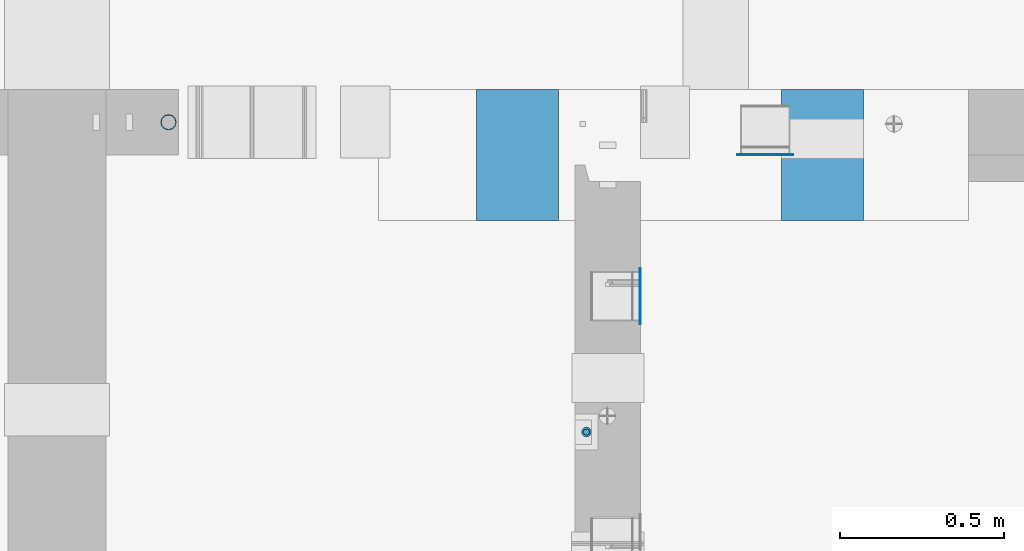
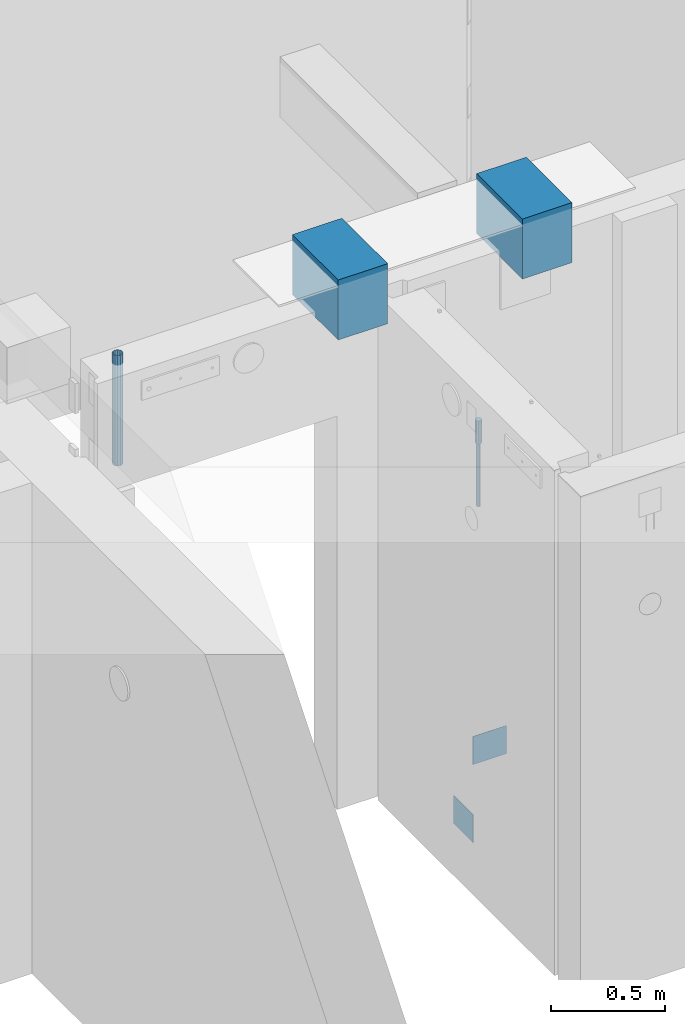
# One storey, part 12 of 264: 7 columns, 6 elements without a shape of their own.
"""IFC2X3 building model written with IfcOpenShell, lengths in millimetres."""

from ifc_helpers import new_model, si_unit, frame, origin_with_axes, place, context, subcontext, project, spatial, faceted_brep, material, type_object, element, aggregate, save


model = new_model("IFC2X3")

# Units and contexts
model_context = context("Model", 3, precision=1e-05, world=origin_with_axes())
body_context = subcontext(model_context, "Body", "Model", "MODEL_VIEW")
ifc_project = project(units=[si_unit("LENGTHUNIT", "METRE", prefix="MILLI"), si_unit("AREAUNIT", "SQUARE_METRE"), si_unit("VOLUMEUNIT", "CUBIC_METRE"), si_unit("MASSUNIT", "GRAM", prefix="KILO"), si_unit("TIMEUNIT", "SECOND"), si_unit("PLANEANGLEUNIT", "RADIAN"), si_unit("SOLIDANGLEUNIT", "STERADIAN"), si_unit("THERMODYNAMICTEMPERATUREUNIT", "DEGREE_CELSIUS"), si_unit("LUMINOUSINTENSITYUNIT", "LUMEN")], contexts=[model_context])

# Site, building, storey
site_placement = place(None, origin_with_axes())
site = spatial("IfcSite", under=ifc_project, at=site_placement, CompositionType="ELEMENT")
building_placement = place(site_placement, origin_with_axes())
building = spatial("IfcBuilding", under=site, at=building_placement, CompositionType="ELEMENT")
storey_placement = place(building_placement, origin_with_axes())
storey = spatial("IfcBuildingStorey", under=building, at=storey_placement, Name="K", CompositionType="ELEMENT", Elevation=0.0)

# Assembly, column
assembly_1_placement = place(storey_placement, origin_with_axes())
assembly_1 = element("IfcElementAssembly", 1, at=assembly_1_placement, inside=storey, AssemblyPlace="NOTDEFINED", PredefinedType="REINFORCEMENT_UNIT")
ifc_material_1 = material()
column_type_1 = type_object("IfcColumnType", Name="D30", PredefinedType="NOTDEFINED")
column_1_placement = place(assembly_1_placement, frame((15165.0, 16035.0017200341, 81167.5), z_axis=(-1.0, 3.00000001838171e-08, 0.0), x_axis=(0.0, 0.0, 1.0)))
column_1 = element("IfcColumn", 2, at=column_1_placement, type_object=column_type_1, material=ifc_material_1, ObjectType="D30", context=body_context, shape_type="Brep", body=[
    faceted_brep([(0.0, -15.0, 0.0), (0.0, -12.9903810567666, -7.5), (125.0, -12.9903810567666, -7.5), (125.0, -15.0, 0.0), (0.0, -7.5, -12.9903810567666), (125.0, -7.5, -12.9903810567666), (0.0, 0.0, -15.0), (125.0, 0.0, -15.0), (0.0, 7.5, -12.9903810567666), (125.0, 7.5, -12.9903810567666), (0.0, 12.9903810567666, -7.5), (125.0, 12.9903810567666, -7.5), (0.0, 15.0, 0.0), (125.0, 15.0, 0.0), (0.0, 12.9903810567666, 7.5), (125.0, 12.9903810567666, 7.5), (0.0, 7.5, 12.9903810567666), (125.0, 7.5, 12.9903810567666), (0.0, 0.0, 15.0), (125.0, 0.0, 15.0), (0.0, -7.5, 12.9903810567666), (125.0, -7.5, 12.9903810567666), (0.0, -12.9903810567666, 7.5), (125.0, -12.9903810567666, 7.5)], [[[0, 1, 2, 3]], [[1, 4, 5, 2]], [[4, 6, 7, 5]], [[6, 8, 9, 7]], [[8, 10, 11, 9]], [[10, 12, 13, 11]], [[12, 14, 15, 13]], [[14, 16, 17, 15]], [[16, 18, 19, 17]], [[18, 20, 21, 19]], [[20, 22, 23, 21]], [[22, 0, 3, 23]], [[5, 7, 9, 11, 13, 15, 17, 19, 21, 23, 3, 2]], [[22, 20, 18, 16, 14, 12, 10, 8, 6, 4, 1, 0]]]),
])

# Assemblies, column
assembly_2_placement = place(storey_placement, origin_with_axes())
assembly_2 = element("IfcElementAssembly", 3, at=assembly_2_placement, inside=storey, AssemblyPlace="NOTDEFINED", PredefinedType="REINFORCEMENT_UNIT")
assembly_3_placement = place(assembly_2_placement, origin_with_axes())
assembly_3 = element("IfcElementAssembly", 4, at=assembly_3_placement, Name="Steel Assembly", AssemblyPlace="NOTDEFINED", PredefinedType="NOTDEFINED")
ifc_material_2 = material(Name="Undefined")
column_type_2 = type_object("IfcColumnType", PredefinedType="NOTDEFINED")
column_2_placement = place(assembly_3_placement, frame((15710.4603214753, 16881.0002441656, 78775.1200050936), z_axis=(0.0, -1.0, 0.0), x_axis=(0.0, 0.0, 1.0)))
column_2 = element("IfcColumn", 5, at=column_2_placement, type_object=column_type_2, material=ifc_material_2, Name="SPK3", context=body_context, shape_type="Brep", body=[
    faceted_brep([(0.0, 85.0, -1.0), (0.0, 85.0, 1.0), (150.0, 85.0, 1.0), (150.0, 85.0, -1.0), (0.0, -85.0, 1.0), (150.0, -85.0, 1.0), (0.0, -85.0, -1.0), (150.0, -85.0, -1.0)], [[[0, 1, 2, 3]], [[1, 4, 5, 2]], [[4, 6, 7, 5]], [[6, 0, 3, 7]], [[5, 7, 3, 2]], [[6, 4, 1, 0]]]),
])
aggregate(assembly_3, [column_2])

# Assembly, column
assembly_4_placement = place(assembly_1_placement, origin_with_axes())
assembly_4 = element("IfcElementAssembly", 6, at=assembly_4_placement, Name="Steel Assembly", AssemblyPlace="NOTDEFINED", PredefinedType="NOTDEFINED")
column_3_placement = place(assembly_4_placement, frame((15328.9997558344, 16449.5113457082, 78775.1200050936), z_axis=(1.0, 0.0, 0.0), x_axis=(0.0, 0.0, 1.0)))
column_3 = element("IfcColumn", 7, at=column_3_placement, type_object=column_type_2, material=ifc_material_2, Name="SPK3", context=body_context, shape_type="Brep", body=[
    faceted_brep([(0.0, 85.0, -1.0), (0.0, 85.0, 1.0), (150.0, 85.0, 1.0), (150.0, 85.0, -1.0), (0.0, -85.0, 1.0), (150.0, -85.0, 1.0), (0.0, -85.0, -1.0), (150.0, -85.0, -1.0)], [[[0, 1, 2, 3]], [[1, 4, 5, 2]], [[4, 6, 7, 5]], [[6, 0, 3, 7]], [[5, 7, 3, 2]], [[6, 4, 1, 0]]]),
])
aggregate(assembly_4, [column_3])

# Column
ifc_material_3 = material()
column_type_3 = type_object("IfcColumnType", Name="48.3X2.6", PredefinedType="NOTDEFINED")
column_4_placement = place(assembly_2_placement, frame((13889.9991042544, 16980.0, 80931.0), z_axis=(-1.0, 3.00000001838171e-08, 0.0), x_axis=(0.0, 0.0, 1.0)))
column_4 = element("IfcColumn", 8, at=column_4_placement, type_object=column_type_3, material=ifc_material_3, ObjectType="48.3X2.6", context=body_context, shape_type="Brep", body=[
    faceted_brep([(0.0, -21.5499999999993, 0.0), (0.0, -18.6628474515564, 10.7750000000015), (589.0, -18.6628474515564, 10.7749999999996), (589.0, -21.5499999999993, 0.0), (0.0, -10.7750000000015, 18.6628474515564), (589.0, -10.7750000000015, 18.6628474515546), (0.0, 0.0, 21.5499999999993), (589.0, 0.0, 21.5499999999993), (0.0, 10.7750000000015, 18.6628474515564), (589.0, 10.7750000000015, 18.6628474515546), (0.0, 18.6628474515564, 10.7750000000015), (589.0, 18.6628474515564, 10.7749999999996), (0.0, 21.5499999999993, 0.0), (589.0, 21.5499999999993, 0.0), (0.0, 18.6628474515564, -10.7750000000015), (589.0, 18.6628474515564, -10.7749999999996), (0.0, 10.7750000000015, -18.6628474515564), (589.0, 10.7750000000015, -18.6628474515546), (0.0, 0.0, -21.5499999999993), (589.0, 0.0, -21.5499999999993), (0.0, -10.7750000000015, -18.6628474515564), (589.0, -10.7750000000015, -18.6628474515546), (0.0, -18.6628474515564, -10.7750000000015), (589.0, -18.6628474515564, -10.7749999999996), (0.0, -24.1500000000015, 0.0), (0.0, -20.9145135013932, -12.0750000000007), (589.0, -20.9145135013932, -12.0750000000007), (589.0, -24.1500000000015, 0.0), (0.0, -12.0750000000007, -20.9145135013932), (589.0, -12.0750000000007, -20.914513501395), (0.0, 0.0, -24.1500000000015), (589.0, 0.0, -24.1499999999996), (0.0, 12.0750000000007, -20.9145135013932), (589.0, 12.0750000000007, -20.914513501395), (0.0, 20.9145135013932, -12.0750000000007), (589.0, 20.9145135013932, -12.0750000000007), (0.0, 24.1500000000015, 0.0), (589.0, 24.1500000000015, 0.0), (0.0, 20.9145135013932, 12.0750000000007), (589.0, 20.9145135013932, 12.0750000000007), (0.0, 12.0750000000007, 20.9145135013932), (589.0, 12.0750000000007, 20.914513501395), (0.0, 0.0, 24.1500000000015), (589.0, 0.0, 24.1499999999996), (0.0, -12.0750000000007, 20.9145135013932), (589.0, -12.0750000000007, 20.914513501395), (0.0, -20.9145135013932, 12.0750000000007), (589.0, -20.9145135013932, 12.0750000000007)], [[[0, 1, 2, 3]], [[1, 4, 5, 2]], [[4, 6, 7, 5]], [[6, 8, 9, 7]], [[8, 10, 11, 9]], [[10, 12, 13, 11]], [[12, 14, 15, 13]], [[14, 16, 17, 15]], [[16, 18, 19, 17]], [[18, 20, 21, 19]], [[20, 22, 23, 21]], [[22, 0, 3, 23]], [[24, 25, 26, 27]], [[25, 28, 29, 26]], [[28, 30, 31, 29]], [[30, 32, 33, 31]], [[32, 34, 35, 33]], [[34, 36, 37, 35]], [[36, 38, 39, 37]], [[38, 40, 41, 39]], [[40, 42, 43, 41]], [[42, 44, 45, 43]], [[44, 46, 47, 45]], [[46, 24, 27, 47]], [[29, 31, 33, 35, 37, 39, 41, 43, 45, 47, 27, 26], [5, 7, 9, 11, 13, 15, 17, 19, 21, 23, 3, 2]], [[46, 44, 42, 40, 38, 36, 34, 32, 30, 28, 25, 24], [22, 20, 18, 16, 14, 12, 10, 8, 6, 4, 1, 0]]]),
])

aggregate(assembly_2, [assembly_3, column_4])

column_type_4 = type_object("IfcColumnType", Name="D20", PredefinedType="NOTDEFINED")
column_5_placement = place(assembly_1_placement, frame((15165.0, 16035.0017200346, 80830.0), z_axis=(-1.0, 3.00000001838171e-08, 0.0), x_axis=(0.0, 0.0, 1.0)))
column_5 = element("IfcColumn", 9, at=column_5_placement, type_object=column_type_4, material=ifc_material_1, Name="JM20", ObjectType="D20", context=body_context, shape_type="Brep", body=[
    faceted_brep([(0.0, -10.0, 0.0), (-4.19531716033816e-08, -7.07106781186667, -7.07106781187031), (337.5, -7.07106781186485, -7.07106781186485), (337.5, -10.0, 0.0), (0.0, 0.0, -10.0), (337.5, 0.0, -10.0), (4.196772351861e-08, 7.07106781186303, -7.07106781186667), (337.5, 7.07106781186485, -7.07106781186485), (0.0, 10.0, 0.0), (337.5, 10.0, 0.0), (4.196772351861e-08, 7.07106781185939, 7.07106781185939), (337.5, 7.07106781186485, 7.07106781186485), (0.0, 0.0, 10.0), (337.5, 0.0, 10.0), (-4.19531716033816e-08, -7.07106781187031, 7.07106781185939), (337.5, -7.07106781186485, 7.07106781186485)], [[[0, 1, 2, 3]], [[1, 4, 5, 2]], [[4, 6, 7, 5]], [[6, 8, 9, 7]], [[8, 10, 11, 9]], [[10, 12, 13, 11]], [[12, 14, 15, 13]], [[14, 0, 3, 15]], [[5, 7, 9, 11, 13, 15, 3, 2]], [[14, 12, 10, 8, 6, 4, 1, 0]]]),
])

aggregate(assembly_1, [column_5, column_1, assembly_4])

# Assembly, column
assembly_5_placement = place(storey_placement, origin_with_axes())
assembly_5 = element("IfcElementAssembly", 10, at=assembly_5_placement, inside=storey, Name="Steel Assembly", AssemblyPlace="NOTDEFINED", PredefinedType="NOTDEFINED")
ifc_material_4 = material()
column_type_5 = type_object("IfcColumnType", PredefinedType="NOTDEFINED")
column_6_placement = place(assembly_5_placement, frame((14955.0035461783, 16880.0006851554, 81440.0), z_axis=(-1.0, 3.00000001838171e-08, 0.0), x_axis=(0.0, 0.0, 1.0)))
column_6 = element("IfcColumn", 11, at=column_6_placement, type_object=column_type_5, material=ifc_material_4, context=body_context, shape_type="Brep", body=[
    faceted_brep([(0.0, 200.0, -125.0), (0.0, 200.0, 125.0), (320.0, 200.0, 125.0), (320.0, 200.0, -125.0), (0.0, -200.0, 125.0), (320.0, -200.0, 125.0), (0.0, -200.0, -125.0), (320.0, -200.0, -125.0)], [[[0, 1, 2, 3]], [[1, 4, 5, 2]], [[4, 6, 7, 5]], [[6, 0, 3, 7]], [[5, 7, 3, 2]], [[6, 4, 1, 0]]]),
])
aggregate(assembly_5, [column_6])

assembly_6_placement = place(storey_placement, origin_with_axes())
assembly_6 = element("IfcElementAssembly", 12, at=assembly_6_placement, inside=storey, Name="Steel Assembly", AssemblyPlace="NOTDEFINED", PredefinedType="NOTDEFINED")
column_7_placement = place(assembly_6_placement, frame((15885.0000366569, 16880.0006851554, 81440.0), z_axis=(-1.0, 3.00000001838171e-08, 0.0), x_axis=(0.0, 0.0, 1.0)))
column_7 = element("IfcColumn", 13, at=column_7_placement, type_object=column_type_5, material=ifc_material_4, context=body_context, shape_type="Brep", body=[
    faceted_brep([(0.0, 200.0, -125.0), (0.0, 200.0, 125.0), (320.0, 200.0, 125.0), (320.0, 200.0, -125.0), (0.0, -200.0, 125.0), (320.0, -200.0, 125.0), (0.0, -200.0, -125.0), (320.0, -200.0, -125.0)], [[[0, 1, 2, 3]], [[1, 4, 5, 2]], [[4, 6, 7, 5]], [[6, 0, 3, 7]], [[5, 7, 3, 2]], [[6, 4, 1, 0]]]),
])
aggregate(assembly_6, [column_7])

save(model, "model.ifc")
